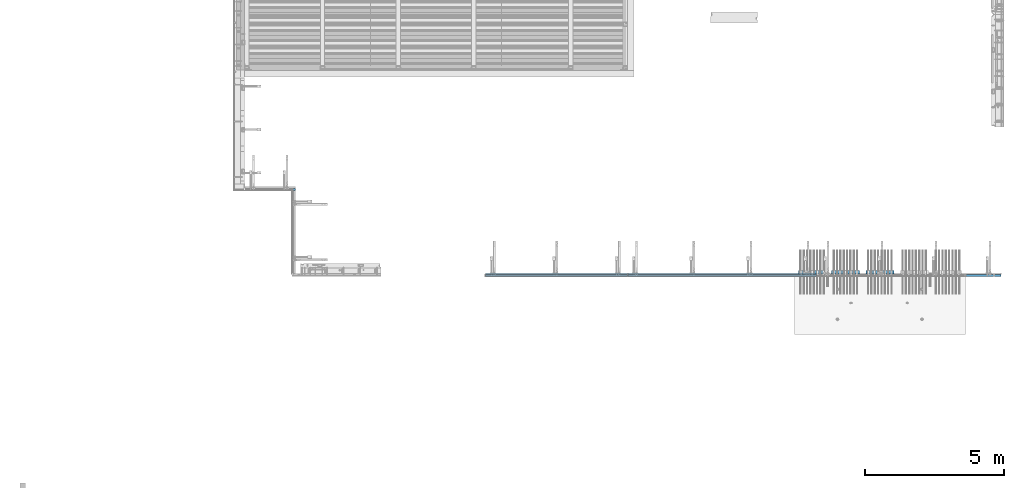
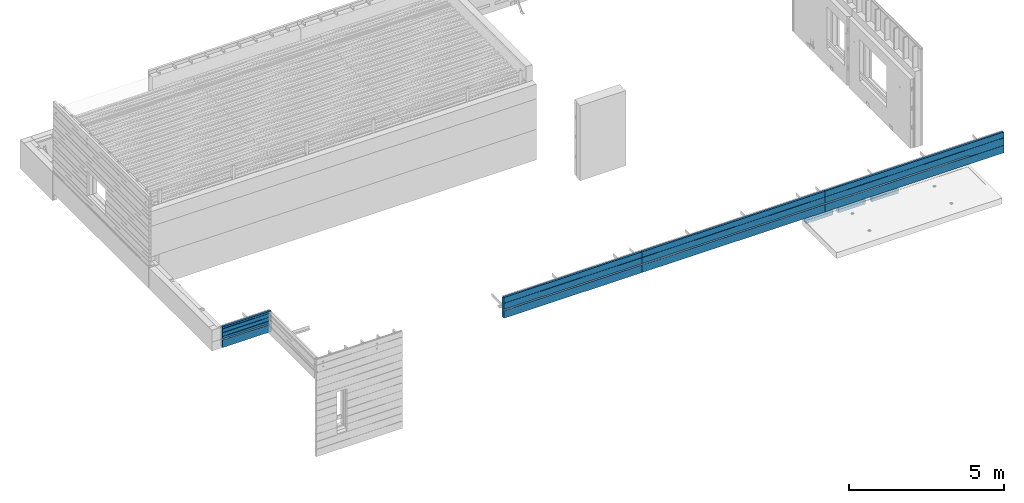
# One storey, part 77 of 153: 7 walls, 8 elements without a shape of their own.
"""IFC2X3 building model written with IfcOpenShell, lengths in millimetres."""

import ifcopenshell
import ifcopenshell.guid

model = None  # the IFC model being written
_history = None  # IfcOwnerHistory: only IFC2X3 demands one
_inside = {}  # id of a spatial element -> (the spatial element, [elements in it])
_under = {}  # id of a project, library or spatial element -> (it, [spatial elements below it])
_declared = {}  # id of a project -> (the project, [libraries it declares])
_typed = {}  # id of a type object -> (the type object, [elements of that type])
_made_of = {}  # id of a material, layer set ... -> (it, [elements and type objects made of it])


def new_model(schema):
    """Start an empty IFC model of exactly this schema.

    Asked for "IFC4X3", IfcOpenShell would pick the latest addendum, in which some entities
    have other attributes; the version numbers below select the first issue.
    IFC2X3 requires an IfcOwnerHistory on every rooted entity: one is made here for all.
    """
    global model, _history
    if schema == "IFC4X3":
        model = ifcopenshell.file(schema_version=(4, 3, 0, 0))
    else:
        model = ifcopenshell.file(schema=schema)
    _inside.clear()
    _under.clear()
    _declared.clear()
    _typed.clear()
    _made_of.clear()
    _history = None
    if model.schema == "IFC2X3":
        org = make("IfcOrganization", Name="unknown")
        user = make(
            "IfcPersonAndOrganization",
            ThePerson=make("IfcPerson", FamilyName="unknown"),
            TheOrganization=org,
        )
        app = make(
            "IfcApplication",
            ApplicationDeveloper=org,
            Version="unknown",
            ApplicationFullName="unknown",
            ApplicationIdentifier="unknown",
        )
        _history = make(
            "IfcOwnerHistory",
            OwningUser=user,
            OwningApplication=app,
            ChangeAction="ADDED",
            CreationDate=0,
        )
    return model


def make(cls, **values):
    """One entity of the class cls with the attributes given. An attribute that is None is left unset."""
    return model.create_entity(
        cls, **{name: value for name, value in values.items() if value is not None}
    )


def rooted(cls, **values):
    """An entity with a GlobalId (a new one), such as an element, a storey or a relation."""
    return make(cls, GlobalId=ifcopenshell.guid.new(), OwnerHistory=_history, **values)


def si_unit(unit_type, name, prefix=None):
    """IfcSIUnit, for example si_unit("LENGTHUNIT", "METRE", prefix="MILLI")."""
    return make("IfcSIUnit", UnitType=unit_type, Prefix=prefix, Name=name)


def assignment(units):
    """IfcUnitAssignment: the units of a project."""
    return None if units is None else make("IfcUnitAssignment", Units=units)


def point(xyz):
    """IfcCartesianPoint."""
    return None if xyz is None else make("IfcCartesianPoint", Coordinates=xyz)


def direction(xyz):
    """IfcDirection."""
    return None if xyz is None else make("IfcDirection", DirectionRatios=xyz)


def frame(location, z_axis=None, x_axis=None):
    """IfcAxis2Placement3D, a coordinate frame: its origin and axes. An axis left out is left unset."""
    return make(
        "IfcAxis2Placement3D",
        Location=point(location),
        Axis=direction(z_axis),
        RefDirection=direction(x_axis),
    )


def origin_with_axes():
    """The frame at (0, 0, 0) with the z axis (0, 0, 1) and the x axis (1, 0, 0) written out."""
    return frame((0.0, 0.0, 0.0), z_axis=(0.0, 0.0, 1.0), x_axis=(1.0, 0.0, 0.0))


def place(relative_to, where):
    """IfcLocalPlacement: puts the frame where relative to a parent placement (None: the world)."""
    return make(
        "IfcLocalPlacement", PlacementRelTo=relative_to, RelativePlacement=where
    )


def context(
    kind, dimensions, precision=None, world=None, true_north=None, identifier=None
):
    """IfcGeometricRepresentationContext, for example the 3D "Model" context."""
    return make(
        "IfcGeometricRepresentationContext",
        ContextIdentifier=identifier,
        ContextType=kind,
        CoordinateSpaceDimension=dimensions,
        Precision=precision,
        WorldCoordinateSystem=world,
        TrueNorth=true_north,
    )


def subcontext(parent, identifier, kind, view, scale=None):
    """IfcGeometricRepresentationSubContext, for example "Body" below "Model"."""
    return make(
        "IfcGeometricRepresentationSubContext",
        ContextIdentifier=identifier,
        ContextType=kind,
        ParentContext=parent,
        TargetScale=scale,
        TargetView=view,
    )


def project(units=None, contexts=None):
    """IfcProject with its units and contexts."""
    return rooted(
        "IfcProject",
        Name="project",
        RepresentationContexts=contexts,
        UnitsInContext=assignment(units),
    )


def spatial(cls, under=None, at=None, **own):
    """A site, building, storey or space (cls), placed at a placement, below another one or the project."""
    s = rooted(cls, ObjectPlacement=at, **own)
    if under is not None:
        _under.setdefault(under.id(), (under, []))[1].append(s)
    return s


def faces_of(points, faces, orient=None, outer=None):
    """IfcFace entities. A face is a list of loops; a loop is a list of indices into points, from 0.

    orient and outer hold one flag for each loop. By default every Orientation is true, the
    first loop of a face is its IfcFaceOuterBound and the others are IfcFaceBound.
    """
    made = []
    for i, loops in enumerate(faces):
        bounds = []
        for j, loop in enumerate(loops):
            is_outer = j == 0 if outer is None else outer[i][j]
            bounds.append(
                make(
                    "IfcFaceOuterBound" if is_outer else "IfcFaceBound",
                    Bound=make("IfcPolyLoop", Polygon=[points[k] for k in loop]),
                    Orientation=True if orient is None else orient[i][j],
                )
            )
        made.append(make("IfcFace", Bounds=bounds))
    return made


def faceted_brep(points, faces, orient=None, outer=None, voids=None):
    """IfcFacetedBrep: a solid bounded by flat faces; with voids (closed shells), ...WithVoids."""
    shared = [point(p) for p in points]
    hull = make("IfcClosedShell", CfsFaces=faces_of(shared, faces, orient, outer))
    if voids is None:
        return make("IfcFacetedBrep", Outer=hull)
    return make(
        "IfcFacetedBrepWithVoids",
        Outer=hull,
        Voids=[
            make(cls, CfsFaces=faces_of(shared, fs, o, b)) for cls, fs, o, b in voids
        ],
    )


def shape(context_of_items, identifier, shape_type, items):
    """IfcShapeRepresentation: the items that make up one representation, for example the "Body"."""
    return make(
        "IfcShapeRepresentation",
        ContextOfItems=context_of_items,
        RepresentationIdentifier=identifier,
        RepresentationType=shape_type,
        Items=items,
    )


def material(Name=None, Category=None):
    """IfcMaterial."""
    return make("IfcMaterial", Name=Name, Category=Category)


def made_of(thing, what):
    """Note that an element or type object is made of a material, layer set ...; save() writes the relation."""
    if what is not None:
        _made_of.setdefault(what.id(), (what, []))[1].append(thing)
    return thing


def type_object(cls, material=None, **own):
    """A type object (cls), such as IfcWallType, which elements share."""
    return made_of(rooted(cls, **own), material)


def element(
    cls,
    number,
    at=None,
    inside=None,
    cuts=None,
    type_object=None,
    material=None,
    context=None,
    identifier="Body",
    shape_type=None,
    held_by="IfcProductDefinitionShape",
    body=None,
    shapes=None,
    **own,
):
    """One element of the class cls, such as IfcWall. Its Tag is "e" and its number.

    at: its placement. inside: the storey or other place that contains it. cuts: it is an
    opening in that element (IfcRelVoidsElement). A single representation is given by context,
    identifier, shape_type and body (its items); several are given by shapes. held_by: the class
    of the entity that holds the representations. save() writes the other relations.
    """
    e = rooted(cls, Tag="e%d" % number, ObjectPlacement=at, **own)
    if body is not None:
        shapes = [shape(context, identifier, shape_type, body)]
    if shapes is not None:
        e.Representation = make(held_by, Representations=shapes)
    if inside is not None:
        _inside.setdefault(inside.id(), (inside, []))[1].append(e)
    if cuts is not None:
        rooted(
            "IfcRelVoidsElement", RelatingBuildingElement=cuts, RelatedOpeningElement=e
        )
    if type_object is not None:
        _typed.setdefault(type_object.id(), (type_object, []))[1].append(e)
    return made_of(e, material)


def aggregate(whole, parts):
    """IfcRelAggregates: a whole, such as a stair, and the parts it consists of."""
    return rooted("IfcRelAggregates", RelatingObject=whole, RelatedObjects=parts)


def save(model, path):
    """Write the relations noted so far, then the file.

    IfcRelAggregates (storeys below a building ...), IfcRelContainedInSpatialStructure (elements
    in a storey), IfcRelDefinesByType, IfcRelAssociatesMaterial and IfcRelDeclares: one each for
    every whole, place, type object, material and project.
    """
    for whole, parts in _under.values():
        aggregate(whole, parts)
    for where, things in _inside.values():
        rooted(
            "IfcRelContainedInSpatialStructure",
            RelatedElements=things,
            RelatingStructure=where,
        )
    for kind, things in _typed.values():
        rooted("IfcRelDefinesByType", RelatedObjects=things, RelatingType=kind)
    for what, things in _made_of.values():
        rooted("IfcRelAssociatesMaterial", RelatedObjects=things, RelatingMaterial=what)
    for by, libraries in _declared.values():
        rooted("IfcRelDeclares", RelatingContext=by, RelatedDefinitions=libraries)
    model.write(path)


model = new_model("IFC2X3")

# Units and contexts
model_context = context("Model", 3, precision=1e-05, world=origin_with_axes())
body_context = subcontext(model_context, "Body", "Model", "MODEL_VIEW")
ifc_project = project(units=[si_unit("LENGTHUNIT", "METRE", prefix="MILLI"), si_unit("AREAUNIT", "SQUARE_METRE"), si_unit("VOLUMEUNIT", "CUBIC_METRE"), si_unit("MASSUNIT", "GRAM", prefix="KILO"), si_unit("TIMEUNIT", "SECOND"), si_unit("PLANEANGLEUNIT", "RADIAN"), si_unit("SOLIDANGLEUNIT", "STERADIAN"), si_unit("THERMODYNAMICTEMPERATUREUNIT", "DEGREE_CELSIUS"), si_unit("LUMINOUSINTENSITYUNIT", "LUMEN")], contexts=[model_context])

# Site, building, storey
site_placement = place(None, origin_with_axes())
site = spatial("IfcSite", under=ifc_project, at=site_placement, CompositionType="ELEMENT")
building_placement = place(site_placement, origin_with_axes())
building = spatial("IfcBuilding", under=site, at=building_placement, CompositionType="ELEMENT")
storey_placement = place(building_placement, origin_with_axes())
storey = spatial("IfcBuildingStorey", under=building, at=storey_placement, Name="8", CompositionType="ELEMENT", Elevation=0.0)

# Assembly, wall
assembly_1_placement = place(storey_placement, origin_with_axes())
assembly_1 = element("IfcElementAssembly", 1, at=assembly_1_placement, inside=storey, AssemblyPlace="NOTDEFINED", PredefinedType="REINFORCEMENT_UNIT")
ifc_material_1 = material(Name="CONCRETE/C30/37")
wall_type_1 = type_object("IfcWallType", PredefinedType="NOTDEFINED")
wall_1_placement = place(assembly_1_placement, frame((9824.99999999999, 10705.0, 103162.5), z_axis=(0.0, 0.0, 1.0), x_axis=(-1.0, 3.00000001838171e-08, 0.0)))
wall_1 = element("IfcWall", 2, at=wall_1_placement, type_object=wall_type_1, material=ifc_material_1, context=body_context, shape_type="Brep", body=[
    faceted_brep([(1809.99994039504, 29.9999999999891, -107.499999999971), (89.9999403950369, 29.9999999999891, -107.5), (89.9999403950369, 29.9999999999891, -57.4999999999709), (1809.99994039504, 29.9999999999891, -57.4999999999709), (89.9999403950369, 59.9999999999891, -107.5), (1809.99994039504, 60.0, -107.499999999971), (89.9999403950369, 59.9999999999891, -57.4999999999709), (1809.99994039504, 60.0, -57.4999999999709), (1809.99994039504, 49.9999992506855, 29.9999999991705), (34.9999999999909, 49.9999992506855, 29.9999999991705), (34.9999999999909, 49.9999991126842, 40.0000004003959), (1809.99994039504, 49.9999991126842, 40.0000004003959), (34.9999999999909, 59.9999992680296, 27.9999999447318), (1809.99994039504, 60.0, 27.9999999447318), (34.9999999999909, 59.9999992431513, 41.9999998892163), (1809.99994039504, 60.0, 41.9999998892163), (1809.99994039504, 49.9999992506855, 179.999999999171), (34.9999999999909, 49.9999992506855, 179.999999999171), (34.9999999999909, 49.9999991126842, 190.000000400396), (1809.99994039504, 49.9999991126842, 190.000000400396), (34.9999999999909, 59.9999992680296, 177.999999944732), (1809.99994039504, 60.0, 177.999999944732), (34.9999999999909, 59.9999992431513, 191.999999889216), (1809.99994039504, 60.0, 191.999999889216), (1809.99994039504, 49.9999992506855, 329.999999999171), (34.9999999999909, 49.9999992506855, 329.999999999171), (34.9999999999909, 49.9999991126842, 340.000000400396), (1809.99994039504, 49.9999991126842, 340.000000400396), (34.9999999999909, 59.9999992680296, 327.999999944732), (1809.99994039504, 60.0, 327.999999944732), (34.9999999999909, 59.9999992431513, 341.999999889216), (1809.99994039504, 60.0, 341.999999889216), (1809.99994039504, 60.0, 407.5), (0.0, 60.0, 407.5), (0.0, -10.0000000000073, 407.5), (1809.99994039504, -10.0000000000073, 407.5), (-9.09494701772928e-12, -10.0000000000073, 357.499999999971), (1809.99994039506, -10.0000000000073, 357.499999999971), (-9.09494701772928e-12, -60.0000000000073, 357.499999999971), (1809.99994039504, -60.0, 357.499999999971), (0.0, 60.0, -407.5), (0.0, -60.0, -407.5), (249.999999999993, -60.0, -269.5), (249.999999999993, -5.0, -269.5), (349.999999999993, -5.0, -269.5), (349.999999999993, -60.0, -269.5), (249.999999999993, -60.0, -407.5), (249.999999999993, -5.0, -407.5), (349.999999999993, -5.0, -407.5), (349.999999999993, -60.0, -407.5), (1559.99994039506, -60.0, -407.5), (1809.99994039504, -60.0, -407.5), (1459.99994039506, -60.0, -407.5), (1459.99994039506, -60.0, -269.5), (1559.99994039506, -60.0, -269.5), (1559.99994039506, -5.0, -407.5), (1559.99994039506, -5.0, -269.5), (1459.99994039506, -5.0, -269.5), (1459.99994039506, -5.0, -407.5), (1809.99994039504, 60.0, -407.5)], [[[0, 1, 2, 3]], [[4, 1, 0, 5]], [[6, 2, 1, 4]], [[7, 3, 2, 6]], [[8, 9, 10, 11]], [[12, 9, 8, 13]], [[14, 10, 9, 12]], [[15, 11, 10, 14]], [[16, 17, 18, 19]], [[20, 17, 16, 21]], [[22, 18, 17, 20]], [[23, 19, 18, 22]], [[24, 25, 26, 27]], [[28, 25, 24, 29]], [[30, 26, 25, 28]], [[31, 27, 26, 30]], [[32, 33, 34, 35]], [[34, 36, 37, 35]], [[38, 39, 37, 36]], [[34, 33, 40, 41, 38, 36]], [[42, 43, 44, 45]], [[46, 47, 43, 42]], [[48, 44, 43, 47]], [[45, 44, 48, 49]], [[50, 51, 39, 38, 41, 46, 42, 45, 49, 52, 53, 54]], [[55, 56, 57, 58]], [[54, 56, 55, 50]], [[53, 57, 56, 54]], [[52, 58, 57, 53]], [[49, 48, 47, 46, 41, 40, 59, 51, 50, 55, 58, 52]], [[13, 8, 11, 15, 21, 16, 19, 23, 29, 24, 27, 31, 32, 35, 37, 39, 51, 59, 5, 0, 3, 7]], [[5, 59, 40, 33, 32, 31, 30, 28, 29, 23, 22, 20, 21, 15, 14, 12, 13, 7, 6, 4]]]),
])
aggregate(assembly_1, [wall_1])

assembly_2_placement = place(storey_placement, origin_with_axes())
assembly_2 = element("IfcElementAssembly", 3, at=assembly_2_placement, inside=storey, AssemblyPlace="NOTDEFINED", PredefinedType="REINFORCEMENT_UNIT")
wall_2_placement = place(assembly_2_placement, frame((21800.0, 7605.0, 103162.5), z_axis=(0.0, 0.0, 1.0), x_axis=(-1.0, 3.00000001838171e-08, 0.0)))
wall_2 = element("IfcWall", 4, at=wall_2_placement, type_object=wall_type_1, material=ifc_material_1, context=body_context, shape_type="Brep", body=[
    faceted_brep([(1.81898940354586e-12, 30.0000000000018, -107.499999999971), (5114.99999999999, 30.0000000000036, -107.5), (5115.0, 60.0, -107.5), (0.0, 60.0, -107.499999999971), (3.63797880709171e-12, 30.0000000000018, -57.4999999999709), (5114.99999999999, 30.0000000000036, -57.5), (0.0, 60.0, -57.4999999999709), (5115.0, 60.0, -57.5), (-9.09494701772928e-13, 49.9999992499179, 179.9999999992), (5115.0, 49.9999992501716, 179.999999999243), (5115.0, 60.0, 177.999999944761), (0.0, 60.0, 177.999999944761), (-9.09494701772928e-13, 49.9999991119166, 190.000000400425), (5115.0, 49.9999991121695, 190.000000400425), (0.0, 60.0, 191.999999889245), (5115.0, 60.0, 191.999999889245), (0.0, 60.0, 407.5), (5115.0, 60.0, 407.5), (0.0, -10.0000000000073, 407.5), (5115.0, -10.0, 407.5), (-9.09494701772928e-12, -10.0000000000073, 357.499999999971), (5115.0, -10.0, 357.5), (-9.09494701772928e-12, -60.0000000000073, 357.499999999971), (5115.0, -60.0, 357.5), (249.999999999993, -60.0, -269.5), (249.999999999993, -5.0, -269.5), (349.999999999993, -5.0, -269.5), (349.999999999993, -60.0, -269.5), (249.999999999993, -60.0, -407.5), (249.999999999993, -5.0, -407.5), (349.999999999993, -5.0, -407.5), (349.999999999993, -60.0, -407.5), (2505.0, -60.0, -269.5), (2505.0, -5.0, -269.5), (2605.0, -5.0, -269.5), (2605.0, -60.0, -269.5), (2505.0, -60.0, -407.5), (2505.0, -5.0, -407.5), (2605.0, -5.0, -407.5), (2605.0, -60.0, -407.5), (4860.0, -60.0, -407.5), (5115.0, -60.0, -407.5), (0.0, -60.0, -407.5), (4760.0, -60.0, -407.5), (4760.0, -60.0, -269.5), (4860.0, -60.0, -269.5), (4860.0, -5.0, -407.5), (4860.0, -5.0, -269.5), (4760.0, -5.0, -269.5), (4760.0, -5.0, -407.5), (0.0, 60.0, -407.5), (5115.0, 60.0, -407.5)], [[[0, 1, 2, 3]], [[4, 5, 1, 0]], [[6, 7, 5, 4]], [[8, 9, 10, 11]], [[12, 13, 9, 8]], [[14, 15, 13, 12]], [[16, 17, 15, 14]], [[17, 16, 18, 19]], [[18, 20, 21, 19]], [[22, 23, 21, 20]], [[24, 25, 26, 27]], [[28, 29, 25, 24]], [[30, 26, 25, 29]], [[27, 26, 30, 31]], [[32, 33, 34, 35]], [[36, 37, 33, 32]], [[38, 34, 33, 37]], [[35, 34, 38, 39]], [[40, 41, 23, 22, 42, 28, 24, 27, 31, 36, 32, 35, 39, 43, 44, 45]], [[46, 47, 48, 49]], [[45, 47, 46, 40]], [[44, 48, 47, 45]], [[43, 49, 48, 44]], [[39, 38, 37, 36, 31, 30, 29, 28, 42, 50, 51, 41, 40, 46, 49, 43]], [[51, 50, 3, 2]], [[10, 9, 13, 15, 17, 19, 21, 23, 41, 51, 2, 1, 5, 7]], [[11, 10, 7, 6]], [[3, 50, 42, 22, 20, 18, 16, 14, 12, 8, 11, 6, 4, 0]]]),
])
aggregate(assembly_2, [wall_2])

assembly_3_placement = place(storey_placement, origin_with_axes())
assembly_3 = element("IfcElementAssembly", 5, at=assembly_3_placement, inside=storey, AssemblyPlace="NOTDEFINED", PredefinedType="REINFORCEMENT_UNIT")
wall_3_placement = place(assembly_3_placement, frame((28603.0, 7605.0, 103162.5), z_axis=(0.0, 0.0, 1.0), x_axis=(-1.0, 3.00000001838171e-08, 0.0)))
wall_3 = element("IfcWall", 6, at=wall_3_placement, type_object=wall_type_1, material=ifc_material_1, context=body_context, shape_type="Brep", body=[
    faceted_brep([(1.81898940354586e-12, 30.0000000000018, -107.499999999971), (6788.0, 30.0000000000036, -107.5), (6788.0, 60.0, -107.5), (0.0, 60.0, -107.499999999971), (3.63797880709171e-12, 30.0000000000018, -57.4999999999709), (6788.0, 30.0000000000036, -57.5), (0.0, 60.0, -57.4999999999709), (6788.0, 60.0, -57.5), (-9.09494701772928e-13, 49.9999992499179, 179.9999999992), (6788.0, 49.9999992501707, 179.999999999229), (6788.0, 60.0, 177.999999944761), (0.0, 60.0, 177.999999944761), (-9.09494701772928e-13, 49.9999991119166, 190.000000400425), (6788.0, 49.9999991121649, 190.000000400425), (0.0, 60.0, 191.999999889245), (6788.0, 60.0, 191.999999889245), (0.0, 60.0, 407.5), (6788.0, 60.0, 407.5), (0.0, -10.0000000000073, 407.5), (6788.0, -10.0, 407.5), (-9.09494701772928e-12, -10.0000000000073, 357.499999999971), (6788.0, -10.0, 357.5), (-9.09494701772928e-12, -60.0000000000073, 357.499999999971), (6788.0, -60.0, 357.5), (249.999999999993, -60.0, -269.5), (249.999999999993, -5.0, -269.5), (349.999999999993, -5.0, -269.5), (349.999999999993, -60.0, -269.5), (249.999999999993, -60.0, -407.5), (249.999999999993, -5.0, -407.5), (349.999999999993, -5.0, -407.5), (349.999999999993, -60.0, -407.5), (2310.0, -60.0, -269.5), (2310.0, -5.0, -269.5), (2410.0, -5.0, -269.5), (2410.0, -60.0, -269.5), (2310.0, -60.0, -407.5), (2310.0, -5.0, -407.5), (2410.0, -5.0, -407.5), (2410.0, -60.0, -407.5), (4370.0, -60.0, -269.5), (4370.0, -5.0, -269.5), (4470.0, -5.0, -269.5), (4470.0, -60.0, -269.5), (4370.0, -60.0, -407.5), (4370.0, -5.0, -407.5), (4470.0, -5.0, -407.5), (4470.0, -60.0, -407.5), (6530.0, -60.0, -407.5), (6788.0, -60.0, -407.5), (0.0, -60.0, -407.5), (6430.0, -60.0, -407.5), (6430.0, -60.0, -269.5), (6530.0, -60.0, -269.5), (6530.0, -5.0, -407.5), (6530.0, -5.0, -269.5), (6430.0, -5.0, -269.5), (6430.0, -5.0, -407.5), (0.0, 60.0, -407.5), (6788.0, 60.0, -407.5)], [[[0, 1, 2, 3]], [[4, 5, 1, 0]], [[6, 7, 5, 4]], [[8, 9, 10, 11]], [[12, 13, 9, 8]], [[14, 15, 13, 12]], [[16, 17, 15, 14]], [[17, 16, 18, 19]], [[18, 20, 21, 19]], [[22, 23, 21, 20]], [[24, 25, 26, 27]], [[28, 29, 25, 24]], [[30, 26, 25, 29]], [[27, 26, 30, 31]], [[32, 33, 34, 35]], [[36, 37, 33, 32]], [[38, 34, 33, 37]], [[35, 34, 38, 39]], [[40, 41, 42, 43]], [[44, 45, 41, 40]], [[46, 42, 41, 45]], [[43, 42, 46, 47]], [[48, 49, 23, 22, 50, 28, 24, 27, 31, 36, 32, 35, 39, 44, 40, 43, 47, 51, 52, 53]], [[54, 55, 56, 57]], [[53, 55, 54, 48]], [[52, 56, 55, 53]], [[51, 57, 56, 52]], [[47, 46, 45, 44, 39, 38, 37, 36, 31, 30, 29, 28, 50, 58, 59, 49, 48, 54, 57, 51]], [[59, 58, 3, 2]], [[10, 9, 13, 15, 17, 19, 21, 23, 49, 59, 2, 1, 5, 7]], [[11, 10, 7, 6]], [[3, 58, 50, 22, 20, 18, 16, 14, 12, 8, 11, 6, 4, 0]]]),
])
aggregate(assembly_3, [wall_3])

assembly_4_placement = place(storey_placement, origin_with_axes())
assembly_4 = element("IfcElementAssembly", 7, at=assembly_4_placement, inside=storey, AssemblyPlace="NOTDEFINED", PredefinedType="REINFORCEMENT_UNIT")
wall_4_placement = place(assembly_4_placement, frame((35260.0, 7605.0, 103162.5), z_axis=(0.0, 0.0, 1.0), x_axis=(-1.0, 3.00000001838171e-08, 0.0)))
wall_4 = element("IfcWall", 8, at=wall_4_placement, type_object=wall_type_1, material=ifc_material_1, context=body_context, shape_type="Brep", body=[
    faceted_brep([(1280.0, 59.9999992675093, -122.000000055239), (1280.0, 49.9999992501698, -120.000000000771), (1280.0, 49.9999991121613, -109.999999599575), (1280.0, 59.9999992426292, -108.000000110755), (0.0, 49.9999992501698, -120.000000000771), (0.0, 60.0, -122.000000055239), (0.0, 49.9999991121613, -109.999999599575), (0.0, 60.0, -108.000000110755), (-9.09494701772928e-13, 49.9999992499179, 179.9999999992), (6643.0, 49.9999992501707, 179.999999999229), (6643.0, 60.0, 177.999999944761), (0.0, 60.0, 177.999999944761), (-9.09494701772928e-13, 49.9999991119166, 190.000000400425), (6643.0, 49.9999991121649, 190.000000400425), (0.0, 60.0, 191.999999889245), (6643.0, 60.0, 191.999999889245), (0.0, 60.0, 407.5), (6643.0, 60.0, 407.5), (0.0, -10.0000000000073, 407.5), (6643.0, -10.0, 407.5), (6643.001115054, 30.2000023799401, -107.5), (1280.00111878334, 30.0000000208793, -107.5), (1280.00111878334, 30.0000000208793, -57.5), (6643.001115054, 30.2000023799401, -57.5), (1279.99999999335, 60.0000000000173, -107.5), (6643.0, 60.0, -107.5), (1279.99999999335, 60.0000000000173, -57.5), (6643.0, 60.0, -57.5), (6643.0, -10.0, 357.5), (6643.0, -60.0, 357.5), (6643.0, -60.0, -407.5), (6643.0, 60.0, -407.5), (-9.09494701772928e-12, -10.0000000000073, 357.499999999971), (-9.09494701772928e-12, -60.0000000000073, 357.499999999971), (349.999999999993, -60.0, -269.5), (349.999999999993, -5.0, -269.5), (450.000000000002, -5.0, -269.5), (450.000000000002, -60.0, -269.5), (349.999999999993, -60.0, -407.5), (349.999999999993, -5.0, -407.5), (450.000000000002, -5.0, -407.5), (450.000000000002, -60.0, -407.5), (2295.0, -60.0, -269.5), (2295.0, -5.0, -269.5), (2395.0, -5.0, -269.5), (2395.0, -60.0, -269.5), (2295.0, -60.0, -407.5), (2295.0, -5.0, -407.5), (2395.0, -5.0, -407.5), (2395.0, -60.0, -407.5), (4240.0, -60.0, -269.5), (4240.0, -5.0, -269.5), (4340.0, -5.0, -269.5), (4340.0, -60.0, -269.5), (4240.0, -60.0, -407.5), (4240.0, -5.0, -407.5), (4340.0, -5.0, -407.5), (4340.0, -60.0, -407.5), (6285.0, -60.0, -407.5), (0.0, -60.0, -407.5), (6185.0, -60.0, -407.5), (6185.0, -60.0, -269.5), (6285.0, -60.0, -269.5), (6285.0, -5.0, -407.5), (6285.0, -5.0, -269.5), (6185.0, -5.0, -269.5), (6185.0, -5.0, -407.5), (0.0, 60.0, -407.5)], [[[0, 1, 2, 3]], [[4, 1, 0, 5]], [[6, 2, 1, 4]], [[7, 3, 2, 6]], [[8, 9, 10, 11]], [[12, 13, 9, 8]], [[14, 15, 13, 12]], [[16, 17, 15, 14]], [[17, 16, 18, 19]], [[20, 21, 22, 23]], [[24, 21, 20, 25]], [[26, 22, 21, 24]], [[27, 23, 22, 26]], [[10, 9, 13, 15, 17, 19, 28, 29, 30, 31, 25, 20, 23, 27]], [[18, 32, 28, 19]], [[33, 29, 28, 32]], [[34, 35, 36, 37]], [[38, 39, 35, 34]], [[40, 36, 35, 39]], [[37, 36, 40, 41]], [[42, 43, 44, 45]], [[46, 47, 43, 42]], [[48, 44, 43, 47]], [[45, 44, 48, 49]], [[50, 51, 52, 53]], [[54, 55, 51, 50]], [[56, 52, 51, 55]], [[53, 52, 56, 57]], [[58, 30, 29, 33, 59, 38, 34, 37, 41, 46, 42, 45, 49, 54, 50, 53, 57, 60, 61, 62]], [[63, 64, 65, 66]], [[62, 64, 63, 58]], [[61, 65, 64, 62]], [[60, 66, 65, 61]], [[57, 56, 55, 54, 49, 48, 47, 46, 41, 40, 39, 38, 59, 67, 31, 30, 58, 63, 66, 60]], [[11, 10, 27, 26, 24, 25, 31, 67, 5, 0, 3, 7]], [[5, 67, 59, 33, 32, 18, 16, 14, 12, 8, 11, 7, 6, 4]]]),
])
aggregate(assembly_4, [wall_4])

# Assemblies, walls
assembly_5_placement = place(storey_placement, origin_with_axes())
assembly_5 = element("IfcElementAssembly", 9, at=assembly_5_placement, inside=storey, AssemblyPlace="NOTDEFINED", PredefinedType="REINFORCEMENT_UNIT")
assembly_6_placement = place(assembly_5_placement, origin_with_axes())
assembly_6 = element("IfcElementAssembly", 10, at=assembly_6_placement, Name="Steel Assembly", AssemblyPlace="NOTDEFINED", PredefinedType="NOTDEFINED")
ifc_material_2 = material()
wall_type_2 = type_object("IfcWallType", PredefinedType="NOTDEFINED")
wall_5_placement = place(assembly_6_placement, frame((30394.9998568133, 7690.00021946163, 102590.0), z_axis=(0.0, 0.0, 1.0), x_axis=(1.0, 0.0, 0.0)))
wall_5 = element("IfcWall", 11, at=wall_5_placement, type_object=wall_type_2, material=ifc_material_2, context=body_context, shape_type="Brep", body=[
    faceted_brep([(0.0, 60.0, -120.0), (0.0, 60.0, 120.0), (1000.0, 60.0, 120.0), (1000.0, 60.0, -120.0), (0.0, -60.0, 120.0), (1000.0, -60.0, 120.0), (0.0, -60.0, -120.0), (1000.0, -60.0, -120.0)], [[[0, 1, 2, 3]], [[1, 4, 5, 2]], [[4, 6, 7, 5]], [[6, 0, 3, 7]], [[5, 7, 3, 2]], [[6, 4, 1, 0]]]),
])
aggregate(assembly_6, [wall_5])
assembly_7_placement = place(assembly_5_placement, origin_with_axes())
assembly_7 = element("IfcElementAssembly", 12, at=assembly_7_placement, Name="Steel Assembly", AssemblyPlace="NOTDEFINED", PredefinedType="NOTDEFINED")
wall_6_placement = place(assembly_7_placement, frame((29154.9998568133, 7690.00021946163, 102590.0), z_axis=(0.0, 0.0, 1.0), x_axis=(1.0, 0.0, 0.0)))
wall_6 = element("IfcWall", 13, at=wall_6_placement, type_object=wall_type_2, material=ifc_material_2, context=body_context, shape_type="Brep", body=[
    faceted_brep([(0.0, 60.0, -120.0), (0.0, 60.0, 120.0), (1000.0, 60.0, 120.0), (1000.0, 60.0, -120.0), (0.0, -60.0, 120.0), (1000.0, -60.0, 120.0), (0.0, -60.0, -120.0), (1000.0, -60.0, -120.0)], [[[0, 1, 2, 3]], [[1, 4, 5, 2]], [[4, 6, 7, 5]], [[6, 0, 3, 7]], [[5, 7, 3, 2]], [[6, 4, 1, 0]]]),
])
aggregate(assembly_7, [wall_6])
assembly_8_placement = place(assembly_5_placement, origin_with_axes())
assembly_8 = element("IfcElementAssembly", 14, at=assembly_8_placement, Name="Steel Assembly", AssemblyPlace="NOTDEFINED", PredefinedType="NOTDEFINED")
aggregate(assembly_5, [assembly_6, assembly_7, assembly_8])
wall_7_placement = place(assembly_8_placement, frame((27954.9998568133, 7690.00021946163, 102590.0), z_axis=(0.0, 0.0, 1.0), x_axis=(1.0, 0.0, 0.0)))
wall_7 = element("IfcWall", 15, at=wall_7_placement, type_object=wall_type_2, material=ifc_material_2, context=body_context, shape_type="Brep", body=[
    faceted_brep([(0.0, 60.0, -120.0), (0.0, 60.0, 120.0), (1000.0, 60.0, 120.0), (1000.0, 60.0, -120.0), (0.0, -60.0, 120.0), (1000.0, -60.0, 120.0), (0.0, -60.0, -120.0), (1000.0, -60.0, -120.0)], [[[0, 1, 2, 3]], [[1, 4, 5, 2]], [[4, 6, 7, 5]], [[6, 0, 3, 7]], [[5, 7, 3, 2]], [[6, 4, 1, 0]]]),
])
aggregate(assembly_8, [wall_7])

save(model, "model.ifc")
